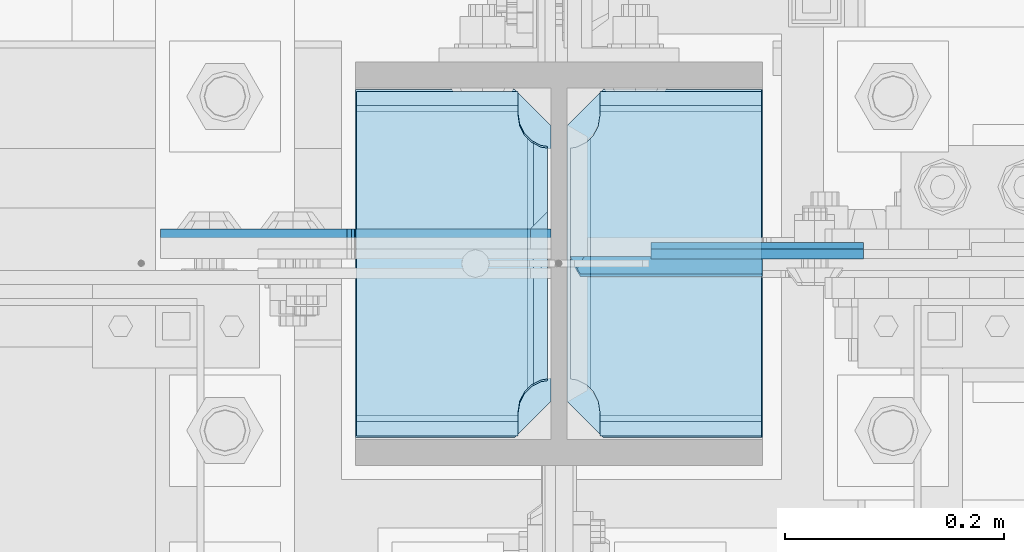
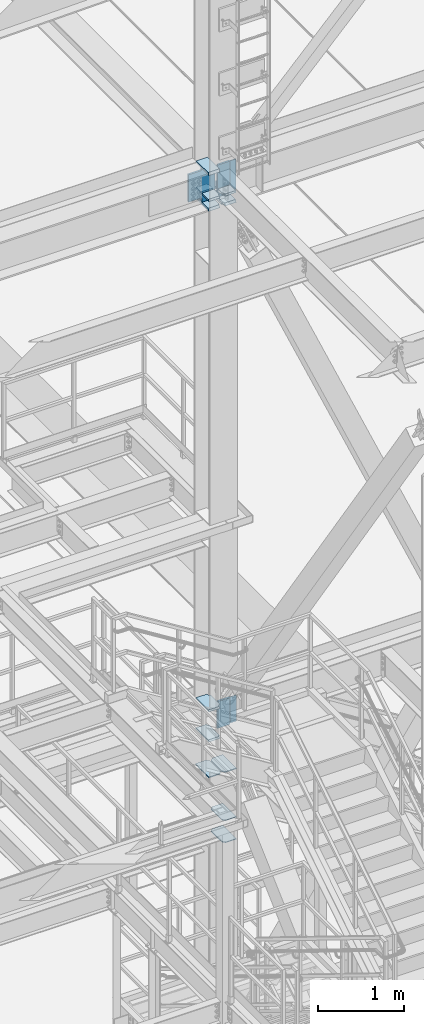
# One storey, part 3149 of 3843: 18 plates, 1 element without a shape of its own.
"""IFC2X3 building model written with IfcOpenShell, lengths in millimetres."""

from ifc_helpers import new_model, si_unit, frame, origin_with_axes, place, context, subcontext, project, spatial, faceted_brep, material, type_object, element, aggregate, save


model = new_model("IFC2X3")

# Units and contexts
model_context = context("Model", 3, precision=1e-05, world=origin_with_axes())
body_context = subcontext(model_context, "Body", "Model", "MODEL_VIEW")
ifc_project = project(units=[si_unit("LENGTHUNIT", "METRE", prefix="MILLI"), si_unit("AREAUNIT", "SQUARE_METRE"), si_unit("VOLUMEUNIT", "CUBIC_METRE"), si_unit("MASSUNIT", "GRAM", prefix="KILO"), si_unit("TIMEUNIT", "SECOND"), si_unit("PLANEANGLEUNIT", "RADIAN"), si_unit("SOLIDANGLEUNIT", "STERADIAN"), si_unit("THERMODYNAMICTEMPERATUREUNIT", "DEGREE_CELSIUS"), si_unit("LUMINOUSINTENSITYUNIT", "LUMEN")], contexts=[model_context])

# Site, building, storey
site_placement = place(None, origin_with_axes())
site = spatial("IfcSite", under=ifc_project, at=site_placement, CompositionType="ELEMENT")
building_placement = place(site_placement, origin_with_axes())
building = spatial("IfcBuilding", under=site, at=building_placement, Name="Undefined", CompositionType="ELEMENT")
storey_placement = place(building_placement, origin_with_axes())
storey = spatial("IfcBuildingStorey", under=building, at=storey_placement, Name="Undefined", CompositionType="ELEMENT", Elevation=0.0)

# Assembly, plates
assembly_placement = place(storey_placement, origin_with_axes())
assembly = element("IfcElementAssembly", 1, at=assembly_placement, inside=storey, Name="COLUMN", AssemblyPlace="NOTDEFINED", PredefinedType="RIGID_FRAME")
ifc_material = material(Name="STEEL/A572-50")
plate_type_1 = type_object("IfcPlateType", PredefinedType="NOTDEFINED")
plate_1_placement = place(assembly_placement, frame((55745.0625, 25457.15, 33854.6736512152), z_axis=(0.0, 1.0, 0.0), x_axis=(1.0, 0.0, 0.0)))
plate_1 = element("IfcPlate", 2, at=plate_1_placement, type_object=plate_type_1, material=ifc_material, Name="STIFFENER", context=body_context, shape_type="Brep", body=[
    faceted_brep([(0.0, -6.3499999046162, 0.0), (0.0, -6.34999999999854, 317.5), (0.0, 6.34999999999854, 317.5), (7.27595761418343e-12, 6.3499999046162, 0.0), (145.256248474121, -6.34999999999854, 317.5), (145.256248474121, 6.34999999999854, 317.5), (178.59375, -6.34999999999854, 284.162498474121), (178.59375, 6.34999999999854, 284.162498474121), (178.59375, -6.34999999999854, 33.3375015258789), (178.59375, 6.34999999999854, 33.3375015258789), (145.256248474121, -6.34999999999854, 0.0), (145.256248474121, 6.34999999999854, 0.0)], [[[0, 1, 2, 3]], [[1, 4, 5, 2]], [[4, 6, 7, 5]], [[6, 8, 9, 7]], [[8, 10, 11, 9]], [[10, 0, 3, 11]], [[5, 7, 9, 11, 3, 2]], [[10, 8, 6, 4, 1, 0]]]),
])
plate_2_placement = place(assembly_placement, frame((55937.94375, 25457.15, 33854.6736512152), z_axis=(0.0, 1.0, 0.0), x_axis=(1.0, 0.0, 0.0)))
plate_2 = element("IfcPlate", 3, at=plate_2_placement, type_object=plate_type_1, material=ifc_material, Name="STIFFENER", context=body_context, shape_type="Brep", body=[
    faceted_brep([(0.0, -6.34999999999854, 33.3375015258789), (0.0, -6.34999999999854, 284.162498474121), (0.0, 6.34999999999854, 284.162498474121), (0.0, 6.34999999999854, 33.3375015258789), (33.3375015258789, -6.34999999999854, 317.5), (33.3375015258789, 6.34999999999854, 317.5), (178.59375, -6.34999999999854, 317.5), (178.59375, 6.34999999999854, 317.5), (178.59375, -6.34999999999854, 0.0), (178.59375, 6.34999999999854, 0.0), (33.3375015258789, -6.34999999999854, 0.0), (33.3375015258789, 6.34999999999854, 0.0)], [[[0, 1, 2, 3]], [[1, 4, 5, 2]], [[4, 6, 7, 5]], [[6, 8, 9, 7]], [[8, 10, 11, 9]], [[10, 0, 3, 11]], [[5, 7, 9, 11, 3, 2]], [[10, 8, 6, 4, 1, 0]]]),
])
plate_type_2 = type_object("IfcPlateType", PredefinedType="NOTDEFINED")
plate_3_placement = place(assembly_placement, frame((55937.94375, 25774.65, 32850.1375), z_axis=(0.0, -1.0, 0.0), x_axis=(1.0, 0.0, 0.0)))
plate_3 = element("IfcPlate", 4, at=plate_3_placement, type_object=plate_type_2, material=ifc_material, Name="PLATE", context=body_context, shape_type="Brep", body=[
    faceted_brep([(0.0, -4.76249999999709, 33.3375015258789), (0.0, -4.76249999999709, 284.162498474121), (0.0, 4.76249999999709, 284.162498474121), (0.0, 4.76249999999709, 33.3375015258789), (33.3375015258789, -4.76249999999709, 317.5), (33.3375015258789, 4.76249999999709, 317.5), (177.800003051758, -4.76249999999709, 317.5), (177.800003051758, 4.76249999999709, 317.5), (177.800000000003, -4.76249999999709, -1.45519152283669e-11), (177.800000000003, 4.76249999999709, -1.45519152283669e-11), (33.3375015258789, -4.76249999999709, 0.0), (33.3375015258789, 4.76249999999709, 0.0)], [[[0, 1, 2, 3]], [[1, 4, 5, 2]], [[4, 6, 7, 5]], [[6, 8, 9, 7]], [[8, 10, 11, 9]], [[10, 0, 3, 11]], [[5, 7, 9, 11, 3, 2]], [[10, 8, 6, 4, 1, 0]]]),
])
plate_4_placement = place(assembly_placement, frame((55937.94375, 25774.65, 33164.4625), z_axis=(0.0, -1.0, 0.0), x_axis=(1.0, 0.0, 0.0)))
plate_4 = element("IfcPlate", 5, at=plate_4_placement, type_object=plate_type_2, material=ifc_material, Name="PLATE", context=body_context, shape_type="Brep", body=[
    faceted_brep([(0.0, -4.76249999999709, 33.3375015258789), (0.0, -4.76249999999709, 284.162498474121), (0.0, 4.76249999999709, 284.162498474121), (0.0, 4.76249999999709, 33.3375015258789), (33.3375015258789, -4.76249999999709, 317.5), (33.3375015258789, 4.76249999999709, 317.5), (177.800003051758, -4.76249999999709, 317.5), (177.800003051758, 4.76249999999709, 317.5), (177.800000000003, -4.76249999999709, -1.45519152283669e-11), (177.800000000003, 4.76249999999709, -1.45519152283669e-11), (33.3375015258789, -4.76249999999709, 0.0), (33.3375015258789, 4.76249999999709, 0.0)], [[[0, 1, 2, 3]], [[1, 4, 5, 2]], [[4, 6, 7, 5]], [[6, 8, 9, 7]], [[8, 10, 11, 9]], [[10, 0, 3, 11]], [[5, 7, 9, 11, 3, 2]], [[10, 8, 6, 4, 1, 0]]]),
])
plate_type_3 = type_object("IfcPlateType", PredefinedType="NOTDEFINED")
plate_5_placement = place(assembly_placement, frame((55923.65625, 25455.5625, 41941.75), z_axis=(0.0, 1.0, 0.0), x_axis=(-1.0, 0.0, 0.0)))
plate_5 = element("IfcPlate", 6, at=plate_5_placement, type_object=plate_type_3, material=ifc_material, Name="PLATE", context=body_context, shape_type="Brep", body=[
    faceted_brep([(17.7290728964945, 9.33285775942204, 270.873024980021), (21.5061209990872, 15.875, 274.650073082623), (21.5061209990872, 15.875, 46.0249269173801), (17.7290728964945, 9.33285775941476, 49.8019750199819), (9.32072521071677, -5.23105698943255, 54.0862421540805), (3.17524995231724, -15.875, 55.0595898134052), (3.17524995231724, -15.875, 265.615410186598), (9.32072521071677, -5.23105698943255, 266.588757845919), (177.799999999996, 15.875, 21.5063709990791), (177.799999999996, -15.875, 3.17549995230729), (30.1625003814697, -15.875, 3.17549995230729), (30.1625003814697, 15.875, 21.5063709990791), (30.1625003814697, 15.875, 299.169629000906), (30.1625003814697, -15.875, 317.500500047678), (177.799999999996, -15.875, 317.500500047678), (177.799999999996, 15.875, 299.169629000906), (9.32072521071677, -15.875, 266.588757845922), (17.7290728964945, -15.875, 270.873024980028), (24.4019754014498, -15.875, 277.545927484985), (24.4019754014498, 15.875, 277.545927484985), (28.6862425355521, -15.875, 285.954275170763), (28.6862425355521, 15.875, 285.954275170763), (30.1625003814697, -15.875, 295.275000381473), (30.1625003814697, 15.875, 295.275000381473), (30.1625003814697, -15.875, 25.3999996185303), (30.1625003814697, 15.875, 25.3999996185303), (28.6862425355521, -15.875, 34.7207248292398), (28.6862425355521, 15.875, 34.7207248292398), (24.4019754014498, -15.875, 43.1290725150175), (24.4019754014498, 15.875, 43.1290725150175), (17.7290728964945, -15.875, 49.8019750199746), (9.32072521071495, -15.875, 54.0862421540805)], [[[0, 1, 2, 3, 4, 5, 6, 7]], [[8, 9, 10, 11]], [[12, 13, 14, 15]], [[16, 7, 6]], [[16, 17, 0, 7]], [[17, 18, 19, 1, 0]], [[18, 20, 21, 19]], [[20, 22, 23, 21]], [[23, 22, 13, 12]], [[15, 14, 9, 8]], [[24, 25, 11, 10]], [[24, 26, 27, 25]], [[26, 28, 29, 27]], [[29, 28, 30, 3, 2]], [[30, 31, 4, 3]], [[31, 5, 4]], [[19, 21, 23, 12, 15, 8, 11, 25, 27, 29, 2, 1]], [[31, 30, 28, 26, 24, 10, 9, 14, 13, 22, 20, 18, 17, 16, 6, 5]]]),
])
plate_6_placement = place(assembly_placement, frame((56115.74375, 25455.5625, 41941.75), z_axis=(0.0, 1.0, 0.0), x_axis=(-1.0, 0.0, 0.0)))
plate_6 = element("IfcPlate", 7, at=plate_6_placement, type_object=plate_type_3, material=ifc_material, Name="PLATE", context=body_context, shape_type="Brep", body=[
    faceted_brep([(160.070927103501, 9.3328577594657, 49.8019750199819), (156.293879000928, 15.875, 46.0249269174055), (156.293879000928, 15.875, 274.650073082594), (160.070927103501, 9.3328577594657, 270.873024980021), (168.479274789279, -5.23105698938161, 266.588757845919), (174.624750047689, -15.875, 265.615398462905), (174.624750047689, -15.875, 55.0595893300633), (168.479274789279, -5.23105698938161, 54.0862421540805), (147.637499618526, 15.875, 21.5063709990791), (147.637499618526, -15.875, 3.17549995230729), (0.0, -15.875, 3.17549995230729), (0.0, 15.875, 21.5063709990791), (0.0, 15.875, 299.169629000906), (0.0, -15.875, 317.500500047678), (147.637499618526, -15.875, 317.500500047678), (147.637499618526, 15.875, 299.169629000906), (147.637499618531, -15.875, 295.275000381473), (147.637499618531, 15.875, 295.275000381473), (149.113757464449, -15.875, 285.954275170763), (149.113757464449, 15.875, 285.954275170763), (153.398024598551, -15.875, 277.545927484985), (153.398024598551, 15.875, 277.545927484985), (160.070927103507, -15.875, 270.873024980028), (168.479274789286, -15.875, 266.588757845922), (168.479274789286, -15.875, 54.0862421540805), (160.070927103507, -15.875, 49.8019750199746), (153.398024598551, -15.875, 43.1290725150175), (153.398024598551, 15.875, 43.1290725150175), (149.113757464449, -15.875, 34.7207248292398), (149.113757464449, 15.875, 34.7207248292398), (147.637499618531, -15.875, 25.3999996185303), (147.637499618531, 15.875, 25.3999996185303)], [[[0, 1, 2, 3, 4, 5, 6, 7]], [[8, 9, 10, 11]], [[12, 13, 14, 15]], [[13, 12, 11, 10]], [[16, 17, 15, 14]], [[16, 18, 19, 17]], [[18, 20, 21, 19]], [[21, 20, 22, 3, 2]], [[22, 23, 4, 3]], [[23, 5, 4]], [[24, 7, 6]], [[24, 25, 0, 7]], [[25, 26, 27, 1, 0]], [[26, 28, 29, 27]], [[28, 30, 31, 29]], [[31, 30, 9, 8]], [[27, 29, 31, 8, 11, 12, 15, 17, 19, 21, 2, 1]], [[9, 30, 28, 26, 25, 24, 6, 5, 23, 22, 20, 18, 16, 14, 13, 10]]]),
])
plate_7_placement = place(assembly_placement, frame((55923.65625, 25455.5625, 42452.925), z_axis=(0.0, 1.0, 0.0), x_axis=(-1.0, 0.0, 0.0)))
plate_7 = element("IfcPlate", 8, at=plate_7_placement, type_object=plate_type_3, material=ifc_material, Name="PLATE", context=body_context, shape_type="Brep", body=[
    faceted_brep([(17.7290728964945, 9.33263080204051, 270.873024980021), (21.5063709990791, 15.875, 274.650323082609), (21.5063709990791, 15.875, 46.0246769173937), (17.7290728964945, 9.33263080204051, 49.8019750199819), (9.32072521071677, -5.23082524805795, 54.0862421540805), (3.17549995231093, -15.875, 55.0595502173092), (3.17549995231093, -15.875, 265.61543757566), (9.32072521071677, -5.23082524805795, 266.588757845919), (30.1625003814697, 15.875, 299.169629000906), (30.1625003814697, -15.875, 317.500500047678), (177.799999999996, -15.875, 317.500500047678), (177.799999999996, 15.875, 299.169629000906), (177.799999999996, 15.875, 21.5063709990791), (177.799999999996, -15.875, 3.17549995230729), (30.1625003814697, -15.875, 3.17549995230729), (30.1625003814697, 15.875, 21.5063709990791), (9.32072521071677, -15.875, 266.588757845922), (17.7290728964945, -15.875, 270.873024980028), (24.4019754014498, -15.875, 277.545927484985), (24.4019754014498, 15.875, 277.545927484985), (28.6862425355521, -15.875, 285.954275170763), (28.6862425355521, 15.875, 285.954275170763), (30.1625003814697, -15.875, 295.275000381473), (30.1625003814697, 15.875, 295.275000381473), (30.1625003814697, -15.875, 25.3999996185303), (30.1625003814697, 15.875, 25.3999996185303), (28.6862425355521, -15.875, 34.7207248292398), (28.6862425355521, 15.875, 34.7207248292398), (24.4019754014498, -15.875, 43.1290725150175), (24.4019754014498, 15.875, 43.1290725150175), (17.7290728964945, -15.875, 49.8019750199746), (9.32072521071495, -15.875, 54.0862421540805)], [[[0, 1, 2, 3, 4, 5, 6, 7]], [[8, 9, 10, 11]], [[12, 13, 14, 15]], [[16, 7, 6]], [[16, 17, 0, 7]], [[17, 18, 19, 1, 0]], [[18, 20, 21, 19]], [[20, 22, 23, 21]], [[23, 22, 9, 8]], [[11, 10, 13, 12]], [[24, 25, 15, 14]], [[24, 26, 27, 25]], [[26, 28, 29, 27]], [[29, 28, 30, 3, 2]], [[30, 31, 4, 3]], [[31, 5, 4]], [[19, 21, 23, 8, 11, 12, 15, 25, 27, 29, 2, 1]], [[31, 30, 28, 26, 24, 14, 13, 10, 9, 22, 20, 18, 17, 16, 6, 5]]]),
])
plate_type_4 = type_object("IfcPlateType", PredefinedType="NOTDEFINED")
plate_8_placement = place(assembly_placement, frame((56208.6125, 25624.63125, 34771.0125), z_axis=(0.0, 0.0, -1.0), x_axis=(-1.0, 0.0, 0.0)))
plate_8 = element("IfcPlate", 9, at=plate_8_placement, type_object=plate_type_4, material=ifc_material, Name="PLATE", context=body_context, shape_type="Brep", body=[
    faceted_brep([(0.0, -4.76249999999709, 0.0), (8.90977389644831e-08, -4.76249999999709, 371.474998644393), (8.90977389644831e-08, 4.76249999999709, 371.474998644393), (0.0, 4.76249999999709, 0.0), (193.675000089086, -4.76249999999709, 371.474998644226), (193.675000089086, 4.76249999999709, 371.474998644226), (193.674999999996, -4.76249999999709, 0.0), (193.674999999996, 4.76249999999709, 0.0)], [[[0, 1, 2, 3]], [[1, 4, 5, 2]], [[4, 6, 7, 5]], [[6, 0, 3, 7]], [[5, 7, 3, 2]], [[6, 4, 1, 0]]]),
])
plate_type_5 = type_object("IfcPlateType", PredefinedType="NOTDEFINED")
plate_9_placement = place(assembly_placement, frame((55937.94375, 25611.93125, 34401.1250026494), z_axis=(0.707106781186548, 0.0, 0.707106781186548), x_axis=(0.707106781186548, 0.0, -0.707106781186548)))
plate_9 = element("IfcPlate", 10, at=plate_9_placement, type_object=plate_type_5, material=ifc_material, Name="PLATE", context=body_context, shape_type="Brep", body=[
    faceted_brep([(-260.427429442954, 7.9375, 264.917557448622), (4.49012799373304, 7.9375, 0.0), (13.4703841824085, -3.06102271161217, -3.63797880709171e-12), (13.4703841830633, -7.9375, 3.98162703275011), (-256.445797883507, -7.93749999884676, 273.897809073191), (-260.427429442972, -3.06101715001205, 273.897809030044), (-138.886955365126, -7.93749996482802, 391.456654946036), (-145.367895964562, 7.9375, 397.937599356294), (-260.427429442987, 7.9375, 282.878060804505), (22.4506403697887, 7.9375, -1.81898940354586e-11), (137.510171880771, 7.93750000091677, 115.059531510957), (131.029230271015, -7.9375, 121.540473120702), (112.81446822444, 7.9375, 139.755234990844), (112.81446822444, -7.9375, 139.755234990844), (-120.672192386237, 7.9375, 373.241892121674), (-120.672192386237, -7.9375, 373.241892121674)], [[[0, 1, 2, 3, 4, 5]], [[6, 7, 8, 5, 4]], [[9, 2, 1]], [[9, 10, 11, 3, 2]], [[12, 13, 11, 10]], [[14, 15, 13, 12]], [[11, 13, 15, 6, 4, 3]], [[8, 0, 5]], [[14, 12, 10, 9, 1, 0, 8, 7]], [[15, 14, 7, 6]]]),
])
plate_type_6 = type_object("IfcPlateType", PredefinedType="NOTDEFINED")
plate_10_placement = place(assembly_placement, frame((56208.6124999996, 25628.6, 42413.2375), z_axis=(0.0, 0.0, -1.0), x_axis=(-1.0, 0.0, 0.0)))
plate_10 = element("IfcPlate", 11, at=plate_10_placement, type_object=plate_type_6, material=ifc_material, Name="PLATE", context=body_context, shape_type="Brep", body=[
    faceted_brep([(0.0, -6.3499999046162, 0.0), (0.0, -6.35000000000582, 431.800000000003), (0.0, 6.35000000000582, 431.800000000003), (7.27595761418343e-12, 6.3499999046162, 0.0), (193.674999999996, -6.35000000000582, 431.800000000003), (193.674999999996, 6.35000000000582, 431.800000000003), (193.674999999996, -6.35000000000582, 0.0), (193.674999999996, 6.35000000000582, 0.0)], [[[0, 1, 2, 3]], [[1, 4, 5, 2]], [[4, 6, 7, 5]], [[6, 0, 3, 7]], [[5, 7, 3, 2]], [[6, 4, 1, 0]]]),
])
plate_type_7 = type_object("IfcPlateType", PredefinedType="NOTDEFINED")
plate_11_placement = place(assembly_placement, frame((55937.94375, 25614.3125, 41976.675), z_axis=(0.707106781186548, 0.0, 0.707106781186548), x_axis=(0.707106781186548, 0.0, -0.707106781186548)))
plate_11 = element("IfcPlate", 12, at=plate_11_placement, type_object=plate_type_7, material=ifc_material, Name="PLATE", context=body_context, shape_type="Brep", body=[
    faceted_brep([(-312.063900187672, 7.9375, 316.553674626761), (4.48977443908552, 7.9375, 0.0), (13.4702065512629, -3.06123817231855, 0.0), (13.470206566004, -7.9375, 3.98145109525649), (-308.082449095031, -7.93749999884676, 325.534106755367), (-312.063900187675, -3.06123817494517, 325.534106741092), (22.4506403697887, 7.9375, -1.81898940354586e-11), (137.510171880771, 7.93750000091677, 115.059531510957), (131.029230271015, -7.9375, 121.540473120702), (-312.063900187676, 7.9375, 334.514540552969), (-190.523427063413, -7.9375, 443.093130455098), (-197.004368674482, 7.9375, 449.574072066178), (-177.921324252063, -7.9375, 430.491027643751), (-177.921324252063, 7.9375, 430.491027643751), (118.427127456042, -7.9375, 134.142575935628), (118.427127456042, 7.9375, 134.142575935628)], [[[0, 1, 2, 3, 4, 5]], [[6, 7, 8, 3, 2]], [[9, 0, 5]], [[10, 11, 9, 5, 4]], [[12, 13, 11, 10]], [[13, 12, 14, 15]], [[1, 0, 9, 11, 13, 15, 7, 6]], [[6, 2, 1]], [[8, 14, 12, 10, 4, 3]], [[15, 14, 8, 7]]]),
])
plate_type_8 = type_object("IfcPlateType", PredefinedType="NOTDEFINED")
plate_12_placement = place(assembly_placement, frame((55923.65625, 25455.5625, 34370.9625), z_axis=(0.0, 1.0, 0.0), x_axis=(-1.0, 0.0, 0.0)))
plate_12 = element("IfcPlate", 13, at=plate_12_placement, type_object=plate_type_8, material=ifc_material, Name="PLATE", context=body_context, shape_type="Brep", body=[
    faceted_brep([(16.0071099052948, 11.1125000000029, 271.583142538795), (16.0071099052948, 11.1125000000029, 49.0918574612078), (9.32072521071677, -0.468658009958745, 52.4987406282016), (3.17549995231093, -11.1125000000029, 53.472048691423), (3.17549995231093, -11.1125000000029, 267.202951308576), (9.32072521071677, -0.468658009958745, 268.176259371798), (30.1625003814697, 11.1125000000029, 304.668890094701), (30.1625003814697, -11.1125000000029, 317.500500047681), (177.799999999996, -11.1125000000029, 317.500500047681), (177.799999999996, 11.1125000000029, 304.668890094701), (177.799999999996, 11.1125000000029, 16.0071099052911), (177.799999999996, -11.1125000000029, 3.17549995231093), (30.1625003814697, -11.1125000000029, 3.17549995231093), (30.1625003814697, 11.1125000000029, 16.0071099052911), (9.32072521071677, -11.1125000000029, 268.176259371798), (17.7290728964945, -11.1125000000029, 272.4605265059), (17.7290728964945, 11.1125000000029, 272.4605265059), (24.4019754014516, -11.1125000000029, 279.133429010853), (24.4019754014516, 11.1125000000029, 279.133429010853), (28.6862425355503, -11.1125000000029, 287.541776696635), (28.6862425355503, 11.1125000000029, 287.541776696635), (30.1625003814697, -11.1125000000029, 296.862501907348), (30.1625003814697, 11.1125000000029, 296.862501907348), (30.1625003814697, -11.1125000000029, 23.8124980926514), (30.1625003814697, 11.1125000000029, 23.8124980926514), (28.6862425355503, -11.1125000000029, 33.1332233033681), (28.6862425355503, 11.1125000000029, 33.1332233033681), (24.4019754014516, -11.1125000000029, 41.5415709891458), (24.4019754014516, 11.1125000000029, 41.5415709891458), (17.7290728964945, -11.1125000000029, 48.214473494103), (17.7290728964945, 11.1125000000029, 48.214473494103), (9.32072521071677, -11.1125000000029, 52.4987406282016)], [[[0, 1, 2, 3, 4, 5]], [[6, 7, 8, 9]], [[10, 11, 12, 13]], [[14, 5, 4]], [[14, 15, 16, 0, 5]], [[15, 17, 18, 16]], [[17, 19, 20, 18]], [[19, 21, 22, 20]], [[22, 21, 7, 6]], [[11, 10, 9, 8]], [[23, 24, 13, 12]], [[23, 25, 26, 24]], [[25, 27, 28, 26]], [[27, 29, 30, 28]], [[30, 29, 31, 2, 1]], [[31, 3, 2]], [[16, 18, 20, 22, 6, 9, 10, 13, 24, 26, 28, 30, 1, 0]], [[31, 29, 27, 25, 23, 12, 11, 8, 7, 21, 19, 17, 15, 14, 4, 3]]]),
])
plate_13_placement = place(assembly_placement, frame((55923.65625, 25455.5625, 34799.5875), z_axis=(0.0, 1.0, 0.0), x_axis=(-1.0, 0.0, 0.0)))
plate_13 = element("IfcPlate", 14, at=plate_13_placement, type_object=plate_type_8, material=ifc_material, Name="PLATE", context=body_context, shape_type="Brep", body=[
    faceted_brep([(16.0068599053047, -11.1125000000029, 49.0919848425619), (16.0068599053047, -11.1125000000029, 271.583015157437), (9.32072521071677, 0.468224997275684, 268.176259371798), (3.17524995232088, 11.1125000000029, 267.202911712469), (3.17524995232088, 11.1125000000029, 53.4720882875336), (9.32072521071677, 0.468224997275684, 52.4987406282016), (30.1625003814697, -11.1125000000029, 23.8124980926514), (28.6862425355503, -11.1125000000029, 33.1332233033681), (28.6862425355503, 11.1125000000029, 33.1332233033681), (30.1625003814697, 11.1125000000029, 23.8124980926514), (24.4019754014516, -11.1125000000029, 41.5415709891458), (24.4019754014516, 11.1125000000029, 41.5415709891458), (17.7290728964945, -11.1125000000029, 48.214473494103), (17.7290728964945, 11.1125000000029, 48.214473494103), (9.32072521071677, 11.1125000000029, 52.4987406282016), (9.32072521071677, 11.1125000000029, 268.176259371798), (17.7290728964945, -11.1125000000029, 272.4605265059), (17.7290728964945, 11.1125000000029, 272.4605265059), (24.4019754014516, -11.1125000000029, 279.133429010853), (24.4019754014516, 11.1125000000029, 279.133429010853), (28.6862425355503, -11.1125000000029, 287.541776696635), (28.6862425355503, 11.1125000000029, 287.541776696635), (30.1625003814697, -11.1125000000029, 296.862501907348), (30.1625003814697, 11.1125000000029, 296.862501907348), (30.1625003814697, -11.1125000000029, 317.500000000015), (30.1625003814697, 11.1125000000029, 304.668390270468), (177.799999999996, -11.1125000000029, 317.500000000015), (177.799999999996, 11.1125000000029, 304.668390270468), (177.799999999996, 11.1125000000029, 16.0066099052965), (30.1625003814697, 11.1125000000029, 16.0066099052965), (30.1625003814697, -11.1125000000029, 3.17499995231628), (177.799999999996, -11.1125000000029, 3.17499995231628)], [[[0, 1, 2, 3, 4, 5]], [[6, 7, 8, 9]], [[7, 10, 11, 8]], [[10, 12, 13, 11]], [[14, 13, 12, 0, 5]], [[14, 5, 4]], [[15, 3, 2]], [[16, 17, 15, 2, 1]], [[16, 18, 19, 17]], [[18, 20, 21, 19]], [[20, 22, 23, 21]], [[23, 22, 24, 25]], [[25, 24, 26, 27]], [[9, 8, 11, 13, 14, 4, 3, 15, 17, 19, 21, 23, 25, 27, 28, 29]], [[6, 9, 29, 30]], [[12, 10, 7, 6, 30, 31, 26, 24, 22, 20, 18, 16, 1, 0]], [[27, 26, 31, 28]], [[28, 31, 30, 29]]]),
])
plate_type_9 = type_object("IfcPlateType", PredefinedType="NOTDEFINED")
plate_14_placement = place(assembly_placement, frame((55937.94375, 25776.2375, 42076.6875), z_axis=(0.0, -1.0, 0.0), x_axis=(1.0, 0.0, 0.0)))
plate_14 = element("IfcPlate", 15, at=plate_14_placement, type_object=plate_type_9, material=ifc_material, Name="PLATE", context=body_context, shape_type="Brep", body=[
    faceted_brep([(177.799999999996, 11.1125000000029, 16.0071099052911), (177.799999999996, -11.1125000000029, 3.17549995231093), (30.1625003814697, -11.1125000000029, 3.17549995231093), (30.1625003814697, 11.1125000000029, 16.0071099052911), (16.0068599052902, 11.1125000000029, 50.6794863684481), (9.32072521071677, -0.468224997253856, 54.0862421540805), (3.17524995230633, -11.1125000000029, 55.0595898134125), (3.17524995230633, -11.1125000000029, 125.412750715241), (16.0068599052902, 11.1125000000029, 138.244360668221), (19.0499992370605, -11.1125000000029, 141.287499999995), (19.0499992370605, 11.1125000000029, 141.287499999995), (177.799999999996, -11.1125000000029, 141.287499999995), (177.799999999996, 11.1125000000029, 141.287499999995), (30.1625003814697, -11.1125000000029, 25.3999996185303), (30.1625003814697, 11.1125000000029, 25.3999996185303), (28.6862425355503, -11.1125000000029, 34.720724829247), (28.6862425355503, 11.1125000000029, 34.720724829247), (24.4019754014516, -11.1125000000029, 43.1290725150247), (24.4019754014516, 11.1125000000029, 43.1290725150247), (17.7290728964945, -11.1125000000029, 49.8019750199819), (17.7290728964945, 11.1125000000029, 49.8019750199819), (9.32072521071677, -11.1125000000029, 54.0862421540805)], [[[0, 1, 2, 3]], [[4, 5, 6, 7, 8]], [[9, 10, 8, 7]], [[9, 11, 12, 10]], [[12, 11, 1, 0]], [[13, 14, 3, 2]], [[13, 15, 16, 14]], [[15, 17, 18, 16]], [[17, 19, 20, 18]], [[20, 19, 21, 5, 4]], [[21, 6, 5]], [[14, 16, 18, 20, 4, 8, 10, 12, 0, 3]], [[21, 19, 17, 15, 13, 2, 1, 11, 9, 7, 6]]]),
])
plate_type_10 = type_object("IfcPlateType", PredefinedType="NOTDEFINED")
plate_15_placement = place(assembly_placement, frame((55937.94375, 25455.5625, 42076.6875), z_axis=(0.0, 1.0, 0.0), x_axis=(1.0, 0.0, 0.0)))
plate_15 = element("IfcPlate", 16, at=plate_15_placement, type_object=plate_type_10, material=ifc_material, Name="PLATE", context=body_context, shape_type="Brep", body=[
    faceted_brep([(30.1625003814697, -11.1125000000029, 16.0066099052965), (30.1625003814697, 11.1125000000029, 3.17499995231628), (177.799999999996, 11.1125000000029, 3.17499995231628), (177.799999999996, -11.1125000000029, 16.0066099052965), (16.0066099053001, -11.1125000000029, 50.6796137498059), (16.0066099053001, -11.1125000000029, 147.769110668236), (3.17499995231628, 11.1125000000029, 134.937500715256), (3.17499995231628, 11.1125000000029, 55.059629409523), (9.32072521071677, 0.467531460562896, 54.0862421540805), (19.0499992370605, -11.1125000000029, 150.8125), (19.0499992370605, 11.1125000000029, 150.8125), (177.799999999996, -11.1125000000029, 150.8125), (177.799999999996, 11.1125000000029, 150.8125), (30.1625003814697, -11.1125000000029, 25.3999996185303), (30.1625003814697, 11.1125000000029, 25.3999996185303), (28.6862425355503, -11.1125000000029, 34.720724829247), (28.6862425355503, 11.1125000000029, 34.720724829247), (24.4019754014516, -11.1125000000029, 43.1290725150247), (24.4019754014516, 11.1125000000029, 43.1290725150247), (17.7290728964945, -11.1125000000029, 49.8019750199819), (17.7290728964945, 11.1125000000029, 49.8019750199819), (9.32072521071677, 11.1125000000029, 54.0862421540805)], [[[0, 1, 2, 3]], [[4, 5, 6, 7, 8]], [[9, 10, 6, 5]], [[9, 11, 12, 10]], [[12, 11, 3, 2]], [[13, 14, 1, 0]], [[13, 15, 16, 14]], [[15, 17, 18, 16]], [[17, 19, 20, 18]], [[21, 20, 19, 4, 8]], [[21, 8, 7]], [[10, 12, 2, 1, 14, 16, 18, 20, 21, 7, 6]], [[11, 9, 5, 4, 19, 17, 15, 13, 0, 3]]]),
])
plate_type_11 = type_object("IfcPlateType", PredefinedType="NOTDEFINED")
plate_16_placement = place(assembly_placement, frame((55923.65625, 25776.2375, 42076.6875), z_axis=(0.0, -1.0, 0.0), x_axis=(-1.0, 0.0, 0.0)))
plate_16 = element("IfcPlate", 17, at=plate_16_placement, type_object=plate_type_11, material=ifc_material, Name="PLATE", context=body_context, shape_type="Brep", body=[
    faceted_brep([(30.1625003814697, -11.1125000000029, 16.0071099052911), (30.1625003814697, 11.1125000000029, 3.17549995231093), (177.799999999996, 11.1125000000029, 3.17549995231093), (177.799999999996, -11.1125000000029, 16.0071099052911), (16.0068599052902, -11.1125000000029, 50.6794863684481), (16.0068599052902, -11.1125000000029, 125.544360477481), (3.17524995230633, 11.1125000000029, 112.712750524501), (3.17524995230633, 11.1125000000029, 55.0595898134125), (9.32072521071677, 0.468224997253856, 54.0862421540805), (19.0499992370605, -11.1125000000029, 128.587499809255), (19.0499992370605, 11.1125000000029, 128.587499809255), (177.799999999996, -11.1125000000029, 128.587499809255), (177.799999999996, 11.1125000000029, 128.587499809255), (30.1625003814697, -11.1125000000029, 25.3999996185303), (30.1625003814697, 11.1125000000029, 25.3999996185303), (28.6862425355503, -11.1125000000029, 34.720724829247), (28.6862425355503, 11.1125000000029, 34.720724829247), (24.4019754014516, -11.1125000000029, 43.1290725150247), (24.4019754014516, 11.1125000000029, 43.1290725150247), (17.7290728964945, -11.1125000000029, 49.8019750199819), (17.7290728964945, 11.1125000000029, 49.8019750199819), (9.32072521071677, 11.1125000000029, 54.0862421540805)], [[[0, 1, 2, 3]], [[4, 5, 6, 7, 8]], [[9, 10, 6, 5]], [[9, 11, 12, 10]], [[12, 11, 3, 2]], [[13, 14, 1, 0]], [[13, 15, 16, 14]], [[15, 17, 18, 16]], [[17, 19, 20, 18]], [[21, 20, 19, 4, 8]], [[21, 8, 7]], [[10, 12, 2, 1, 14, 16, 18, 20, 21, 7, 6]], [[11, 9, 5, 4, 19, 17, 15, 13, 0, 3]]]),
])
plate_type_12 = type_object("IfcPlateType", PredefinedType="NOTDEFINED")
plate_17_placement = place(assembly_placement, frame((55923.65625, 25455.5625, 42076.6875), z_axis=(0.0, 1.0, 0.0), x_axis=(-1.0, 0.0, 0.0)))
plate_17 = element("IfcPlate", 18, at=plate_17_placement, type_object=plate_type_12, material=ifc_material, Name="PLATE", context=body_context, shape_type="Brep", body=[
    faceted_brep([(177.799999999996, 11.1125000000029, 16.0066099052965), (177.799999999996, -11.1125000000029, 3.17499995231628), (30.1625003814697, -11.1125000000029, 3.17499995231628), (30.1625003814697, 11.1125000000029, 16.0066099052965), (16.0066099053001, 11.1125000000029, 50.6796137498059), (9.32072521071677, -0.467531460562896, 54.0862421540805), (3.17499995231628, -11.1125000000029, 55.059629409523), (3.17499995231628, -11.1125000000029, 150.812500905988), (16.0066099053001, 11.1125000000029, 163.644110858968), (19.0499992370605, -11.1125000000029, 166.687500190732), (19.0499992370605, 11.1125000000029, 166.687500190732), (177.799999999996, -11.1125000000029, 166.687500190732), (177.799999999996, 11.1125000000029, 166.687500190732), (30.1625003814697, -11.1125000000029, 25.3999996185303), (30.1625003814697, 11.1125000000029, 25.3999996185303), (28.6862425355503, -11.1125000000029, 34.720724829247), (28.6862425355503, 11.1125000000029, 34.720724829247), (24.4019754014516, -11.1125000000029, 43.1290725150247), (24.4019754014516, 11.1125000000029, 43.1290725150247), (17.7290728964945, -11.1125000000029, 49.8019750199819), (17.7290728964945, 11.1125000000029, 49.8019750199819), (9.32072521071677, -11.1125000000029, 54.0862421540805)], [[[0, 1, 2, 3]], [[4, 5, 6, 7, 8]], [[9, 10, 8, 7]], [[9, 11, 12, 10]], [[12, 11, 1, 0]], [[13, 14, 3, 2]], [[13, 15, 16, 14]], [[15, 17, 18, 16]], [[17, 19, 20, 18]], [[20, 19, 21, 5, 4]], [[21, 6, 5]], [[14, 16, 18, 20, 4, 8, 10, 12, 0, 3]], [[21, 19, 17, 15, 13, 2, 1, 11, 9, 7, 6]]]),
])
plate_type_13 = type_object("IfcPlateType", PredefinedType="NOTDEFINED")
plate_18_placement = place(assembly_placement, frame((55923.65625, 25634.9500001907, 41976.675), z_axis=(-0.707106781186548, 0.0, 0.707106781186548), x_axis=(-0.707106781186548, 0.0, -0.707106781186548)))
plate_18 = element("IfcPlate", 19, at=plate_18_placement, type_object=plate_type_13, material=ifc_material, Name="PLATE", context=body_context, shape_type="Brep", body=[
    faceted_brep([(0.0, -12.6999999999971, 0.0), (-312.063900205641, -12.7000000000007, 312.063900205645), (-312.063900205641, 12.7000000000007, 312.063900205645), (0.0, 12.6999999999971, 0.0), (-312.063900205627, -12.7000000000007, 339.004668568734), (-312.063900205627, 12.7000000000007, 339.004668568734), (-199.249432685232, -12.7000000000007, 451.819136089121), (-199.249432685232, 12.7000000000007, 451.819136089121), (-190.26917642937, -12.7000000000007, 442.838879833249), (-190.26917642937, 12.7000000000007, 442.838879833249), (-186.148999961224, -12.7000000000007, 440.085865932775), (-186.148999961224, 12.7000000000007, 440.085865932775), (-181.288920443185, -12.7000000000007, 439.119136010191), (-181.288920443185, 12.7000000000007, 439.119136010191), (-176.42884092516, -12.7000000000007, 440.085865932771), (-176.42884092516, 12.7000000000007, 440.085865932771), (-172.308664457014, -12.7000000000007, 442.838879833249), (-172.308664457014, 12.7000000000007, 442.838879833249), (-55.565334748826, -12.7000000000007, 559.58220954143), (-55.565334748826, 12.7000000000007, 559.58220954143), (222.822605002977, -12.7000000000007, 281.194269789627), (222.822605002977, 12.7000000000007, 281.194269789627), (106.079275294789, -12.7000000000007, 164.450940081439), (106.079275294789, 12.7000000000007, 164.450940081439), (103.326261394308, -12.7000000000007, 160.330763613296), (103.326261394308, 12.7000000000007, 160.330763613296), (102.359531471739, -12.7000000000007, 155.470684095257), (102.359531471739, 12.7000000000007, 155.470684095257), (103.326261394308, -12.7000000000007, 150.610604577232), (103.326261394308, 12.7000000000007, 150.610604577232), (106.079275294789, -12.7000000000007, 146.490428109086), (106.079275294789, 12.7000000000007, 146.490428109086), (139.755235883495, -12.7000000000007, 112.814467520391), (139.755235883495, 12.7000000000007, 112.814467520391), (26.9407683630998, -12.7000000000007, 3.63797880709171e-12), (26.9407683630998, 12.7000000000007, 3.63797880709171e-12)], [[[0, 1, 2, 3]], [[1, 4, 5, 2]], [[4, 6, 7, 5]], [[6, 8, 9, 7]], [[8, 10, 11, 9]], [[10, 12, 13, 11]], [[12, 14, 15, 13]], [[14, 16, 17, 15]], [[16, 18, 19, 17]], [[18, 20, 21, 19]], [[20, 22, 23, 21]], [[22, 24, 25, 23]], [[24, 26, 27, 25]], [[26, 28, 29, 27]], [[28, 30, 31, 29]], [[30, 32, 33, 31]], [[32, 34, 35, 33]], [[34, 0, 3, 35]], [[5, 7, 9, 11, 13, 15, 17, 19, 21, 23, 25, 27, 29, 31, 33, 35, 3, 2]], [[34, 32, 30, 28, 26, 24, 22, 20, 18, 16, 14, 12, 10, 8, 6, 4, 1, 0]]]),
])
aggregate(assembly, [plate_8, plate_9, plate_10, plate_11, plate_3, plate_4, plate_14, plate_15, plate_16, plate_17, plate_5, plate_6, plate_18, plate_7, plate_12, plate_13, plate_1, plate_2])

save(model, "model.ifc")
